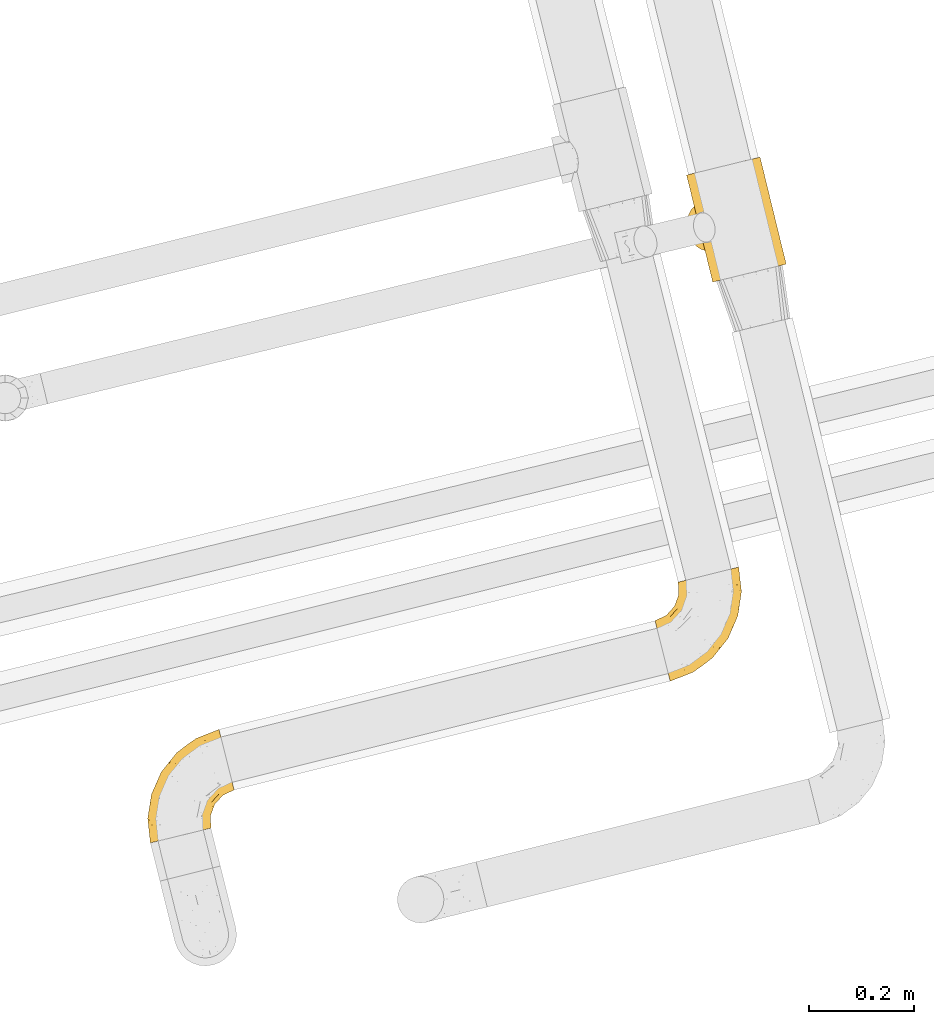
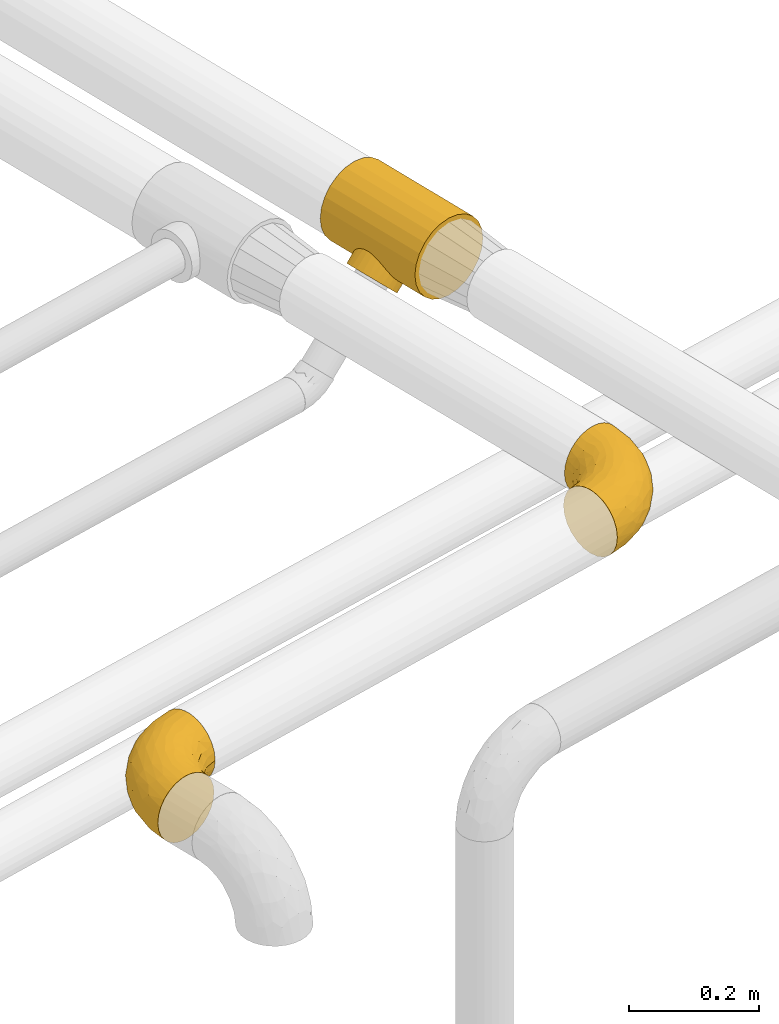
# One storey, part 6 of 93: 3 coverings.
"""IFC2X3 building model written with IfcOpenShell, lengths in millimetres."""

from ifc_helpers import new_model, entity, si_unit, converted_unit, derived_unit, direction, frame, origin, place, context, subcontext, project, spatial, faceted_brep, element, save


model = new_model("IFC2X3")

# Units and contexts
model_context = context("Model", 3, precision=0.01, world=origin(), true_north=direction((6.12303176911189e-17, 1.0)))
body_context = subcontext(model_context, "Body", "Model", "MODEL_VIEW")
ifc_project = project(units=[si_unit("LENGTHUNIT", "METRE", prefix="MILLI"), si_unit("AREAUNIT", "SQUARE_METRE"), si_unit("VOLUMEUNIT", "CUBIC_METRE"), converted_unit("PLANEANGLEUNIT", "DEGREE", entity("IfcRatioMeasure", 0.0174532925199433), si_unit("PLANEANGLEUNIT", "RADIAN"), dimensions=[0, 0, 0, 0, 0, 0, 0]), si_unit("MASSUNIT", "GRAM", prefix="KILO"), derived_unit("MASSDENSITYUNIT", [(si_unit("MASSUNIT", "GRAM", prefix="KILO"), 1), (si_unit("LENGTHUNIT", "METRE"), -3)]), derived_unit("MOMENTOFINERTIAUNIT", [(si_unit("LENGTHUNIT", "METRE"), 4)]), si_unit("TIMEUNIT", "SECOND"), si_unit("FREQUENCYUNIT", "HERTZ"), si_unit("THERMODYNAMICTEMPERATUREUNIT", "DEGREE_CELSIUS"), derived_unit("THERMALTRANSMITTANCEUNIT", [(si_unit("MASSUNIT", "GRAM", prefix="KILO"), 1), (si_unit("THERMODYNAMICTEMPERATUREUNIT", "KELVIN"), -1), (si_unit("TIMEUNIT", "SECOND"), -3)]), derived_unit("VOLUMETRICFLOWRATEUNIT", [(si_unit("LENGTHUNIT", "METRE"), 3), (si_unit("TIMEUNIT", "SECOND"), -1)]), derived_unit("MASSFLOWRATEUNIT", [(si_unit("MASSUNIT", "GRAM", prefix="KILO"), 1), (si_unit("TIMEUNIT", "SECOND"), -1)]), derived_unit("ROTATIONALFREQUENCYUNIT", [(si_unit("TIMEUNIT", "SECOND"), -1)]), si_unit("ELECTRICCURRENTUNIT", "AMPERE"), si_unit("ELECTRICVOLTAGEUNIT", "VOLT"), si_unit("POWERUNIT", "WATT"), si_unit("FORCEUNIT", "NEWTON", prefix="KILO"), si_unit("ILLUMINANCEUNIT", "LUX"), si_unit("LUMINOUSFLUXUNIT", "LUMEN"), si_unit("LUMINOUSINTENSITYUNIT", "CANDELA"), derived_unit("USERDEFINED", [(si_unit("MASSUNIT", "GRAM", prefix="KILO"), -1), (si_unit("LENGTHUNIT", "METRE"), -2), (si_unit("TIMEUNIT", "SECOND"), 3), (si_unit("LUMINOUSFLUXUNIT", "LUMEN"), 1)]), derived_unit("LINEARVELOCITYUNIT", [(si_unit("LENGTHUNIT", "METRE"), 1), (si_unit("TIMEUNIT", "SECOND"), -1)]), si_unit("PRESSUREUNIT", "PASCAL"), derived_unit("USERDEFINED", [(si_unit("LENGTHUNIT", "METRE"), -2), (si_unit("MASSUNIT", "GRAM", prefix="KILO"), 1), (si_unit("TIMEUNIT", "SECOND"), -2)]), derived_unit("LINEARFORCEUNIT", [(si_unit("MASSUNIT", "GRAM", prefix="KILO"), 1), (si_unit("LENGTHUNIT", "METRE"), 1), (si_unit("TIMEUNIT", "SECOND"), -2), (si_unit("LENGTHUNIT", "METRE"), -1)]), derived_unit("PLANARFORCEUNIT", [(si_unit("MASSUNIT", "GRAM", prefix="KILO"), 1), (si_unit("LENGTHUNIT", "METRE"), 1), (si_unit("TIMEUNIT", "SECOND"), -2), (si_unit("LENGTHUNIT", "METRE"), -2)])], contexts=[model_context])

# Site, building, storey
site_placement = place(None, origin())
site = spatial("IfcSite", under=ifc_project, at=site_placement, CompositionType="ELEMENT")
building_placement = place(site_placement, origin())
building = spatial("IfcBuilding", under=site, at=building_placement, CompositionType="ELEMENT")
storey_placement = place(building_placement, frame((0.0, 0.0, -4200.0)))
storey = spatial("IfcBuildingStorey", under=building, at=storey_placement, CompositionType="ELEMENT", Elevation=-4200.0)

# Coverings
covering_1_placement = place(storey_placement, frame((-16263.21, 9717.74, 2404.11)))
element("IfcCovering", 1, at=covering_1_placement, inside=storey, Name=":ADSK_", ObjectType=":ADSK_", PredefinedType="INSULATION", context=body_context, shape_type="Brep", body=[
    faceted_brep([(60.8, 3.9, 132.57), (53.8, 2.19, 115.17), (51.41, 1.6, 96.5), (53.8, 2.17, 77.82), (57.3, 3.02, 69.12), (60.8, 3.87, 60.42), (66.37, 5.23, 52.95), (71.94, 6.59, 45.48), (79.2, 8.36, 39.75), (86.46, 10.13, 34.01), (94.91, 12.19, 30.41), (103.37, 14.25, 26.81), (121.51, 18.68, 24.35), (139.65, 23.11, 26.8), (156.55, 27.24, 34.01), (171.07, 30.79, 45.48), (182.21, 33.52, 60.42), (189.21, 35.24, 77.82), (191.59, 35.83, 96.5), (189.2, 35.25, 115.17), (182.2, 33.55, 132.57), (171.06, 30.83, 147.51), (156.54, 27.29, 158.98), (139.64, 23.17, 166.19), (121.49, 18.74, 168.65), (103.35, 14.31, 166.19), (86.45, 10.18, 158.98), (71.94, 6.63, 147.51), (121.25, 234.8, 45.39), (106.74, 231.25, 33.93), (89.83, 227.12, 26.72), (71.69, 222.69, 24.26), (53.55, 218.26, 26.72), (45.1, 216.2, 30.32), (36.65, 214.13, 33.93), (29.39, 212.36, 39.66), (22.13, 210.59, 45.39), (16.56, 209.24, 52.86), (10.99, 207.88, 60.34), (7.49, 207.03, 69.04), (3.99, 206.18, 77.74), (1.6, 205.6, 96.41), (3.98, 206.19, 115.08), (10.98, 207.91, 132.49), (22.12, 210.63, 147.43), (36.63, 214.18, 158.89), (53.54, 218.31, 166.1), (71.68, 222.75, 168.56), (89.82, 227.17, 166.1), (106.73, 231.3, 158.89), (121.24, 234.84, 147.43), (132.38, 237.55, 132.49), (139.39, 239.26, 115.08), (141.78, 239.83, 96.41), (139.39, 239.24, 77.74), (132.39, 237.52, 60.34), (36.33, 152.45, 45.42), (57.75, 64.73, 45.45), (44.21, 153.14, 38.65), (53.05, 151.76, 33.31), (70.92, 143.42, 26.99), (62.15, 148.46, 29.48), (65.06, 67.74, 38.68), (72.27, 73.04, 33.34), (78.83, 80.17, 29.51), (84.29, 88.68, 27.02), (78.78, 136.74, 25.57), (85.06, 128.46, 24.91), (88.96, 118.82, 24.73), (88.18, 98.23, 25.59), (89.94, 108.47, 24.92), (23.04, 123.15, 82.94), (44.88, 66.37, 61.53), (39.89, 70.67, 69.59), (24.66, 113.73, 87.08), (30.03, 149.69, 53.24), (26.92, 103.7, 88.59), (29.54, 93.75, 87.09), (50.88, 64.29, 53.28), (32.44, 84.64, 82.96), (23.21, 138.96, 69.56), (22.45, 131.6, 76.89), (25.66, 145.08, 61.5), (35.81, 76.86, 76.91), (68.2, 101.71, 2.69), (67.68, 90.38, 5.88), (64.97, 80.09, 10.96), (60.25, 71.56, 17.57), (53.84, 65.35, 25.28), (46.17, 61.9, 33.54), (37.78, 61.44, 41.8), (29.23, 63.99, 49.5), (21.1, 69.4, 56.11), (13.96, 77.28, 61.18), (8.27, 87.1, 64.36), (4.45, 98.2, 65.45), (2.73, 109.81, 64.35), (3.25, 121.14, 61.16), (5.96, 131.43, 56.08), (10.68, 139.96, 49.47), (17.09, 146.17, 41.77), (24.75, 149.62, 33.5), (33.15, 150.08, 25.24), (41.7, 147.53, 17.54), (49.82, 142.12, 10.93), (56.97, 134.24, 5.86), (62.65, 124.41, 2.68), (66.48, 113.32, 1.6)], [[[0, 1, 2, 3, 4, 5, 6, 7, 8, 9, 10, 11, 12, 13, 14, 15, 16, 17, 18, 19, 20, 21, 22, 23, 24, 25, 26, 27]], [[28, 29, 30, 31, 32, 33, 34, 35, 36, 37, 38, 39, 40, 41, 42, 43, 44, 45, 46, 47, 48, 49, 50, 51, 52, 53, 54, 55]], [[35, 56, 36]], [[57, 8, 7]], [[58, 35, 34]], [[34, 59, 58]], [[34, 33, 59]], [[32, 60, 61]], [[61, 33, 32]], [[57, 62, 8]], [[63, 10, 9]], [[63, 64, 10]], [[63, 9, 62]], [[64, 65, 11]], [[66, 31, 67]], [[31, 66, 32]], [[56, 35, 58]], [[59, 33, 61]], [[30, 29, 14, 13]], [[12, 31, 30, 13]], [[67, 31, 68]], [[14, 29, 28, 15]], [[12, 69, 70]], [[62, 9, 8]], [[12, 11, 69]], [[11, 65, 69]], [[70, 68, 12]], [[64, 11, 10]], [[68, 31, 12]], [[66, 60, 32]], [[16, 55, 54, 17]], [[17, 54, 53, 18]], [[28, 55, 16, 15]], [[19, 52, 51, 20]], [[20, 51, 50, 21]], [[18, 53, 52, 19]], [[22, 49, 48, 23]], [[23, 48, 47, 24]], [[50, 49, 22, 21]], [[25, 46, 45, 26]], [[26, 45, 44, 27]], [[24, 47, 46, 25]], [[43, 0, 27, 44]], [[42, 1, 0, 43]], [[41, 40, 71]], [[72, 4, 73]], [[71, 74, 41]], [[75, 38, 37]], [[42, 41, 2, 1]], [[41, 74, 76]], [[76, 77, 2]], [[57, 6, 78]], [[2, 79, 3]], [[79, 2, 77]], [[80, 40, 39]], [[2, 41, 76]], [[71, 40, 81]], [[81, 40, 80]], [[80, 39, 82]], [[36, 56, 37]], [[57, 7, 6]], [[75, 37, 56]], [[38, 75, 82]], [[38, 82, 39]], [[83, 73, 3]], [[4, 72, 5]], [[73, 4, 3]], [[3, 79, 83]], [[6, 5, 78]], [[78, 5, 72]], [[84, 85, 86, 87, 88, 89, 90, 91, 92, 93, 94, 95, 96, 97, 98, 99, 100, 101, 102, 103, 104, 105, 106, 107]], [[62, 89, 88]], [[63, 88, 87]], [[62, 57, 89]], [[64, 63, 87]], [[62, 88, 63]], [[87, 86, 64]], [[86, 85, 65]], [[85, 84, 69]], [[70, 84, 107]], [[65, 85, 69]], [[70, 69, 84]], [[68, 70, 107]], [[86, 65, 64]], [[67, 107, 106]], [[66, 106, 105]], [[68, 107, 67]], [[67, 106, 66]], [[105, 60, 66]], [[105, 104, 60]], [[61, 104, 103]], [[102, 101, 58]], [[59, 103, 102]], [[59, 61, 103]], [[56, 58, 101]], [[59, 102, 58]], [[104, 61, 60]], [[75, 101, 100]], [[82, 100, 99]], [[75, 56, 101]], [[80, 82, 99]], [[75, 100, 82]], [[99, 98, 80]], [[81, 98, 97]], [[97, 96, 71]], [[95, 74, 96]], [[81, 97, 71]], [[74, 71, 96]], [[76, 74, 95]], [[98, 81, 80]], [[77, 95, 94]], [[79, 94, 93]], [[76, 95, 77]], [[77, 94, 79]], [[93, 83, 79]], [[93, 92, 83]], [[73, 92, 91]], [[91, 90, 72]], [[89, 78, 90]], [[72, 73, 91]], [[57, 78, 89]], [[72, 90, 78]], [[92, 73, 83]]]),
])
covering_2_placement = place(storey_placement, frame((-16323.33, 8956.47, 2438.9)))
element("IfcCovering", 2, at=covering_2_placement, inside=storey, Name=":ADSK_", ObjectType=":ADSK_", PredefinedType="INSULATION", context=body_context, shape_type="Brep", body=[
    faceted_brep([(103.39, 204.82, 120.6), (116.24, 208.03, 119.1), (128.44, 211.07, 114.7), (139.39, 213.8, 107.61), (148.53, 216.08, 98.19), (155.4, 217.8, 86.9), (159.67, 218.87, 74.32), (161.12, 219.23, 61.1), (159.67, 218.87, 47.85), (155.4, 217.8, 35.28), (148.52, 216.08, 23.99), (139.38, 213.8, 14.57), (128.43, 211.07, 7.48), (116.22, 208.02, 3.08), (103.39, 204.82, 1.6), (90.54, 201.61, 3.09), (78.34, 198.57, 7.49), (67.39, 195.84, 14.58), (58.25, 193.55, 24.0), (51.37, 191.84, 35.29), (47.1, 190.77, 47.87), (45.66, 190.41, 61.1), (47.11, 190.77, 74.34), (51.38, 191.84, 86.92), (58.26, 193.56, 98.2), (67.4, 195.84, 107.62), (78.35, 198.57, 114.71), (90.55, 201.62, 119.11), (2.09, 115.09, 45.7), (3.52, 109.33, 31.35), (5.81, 100.15, 19.02), (8.79, 88.19, 9.57), (12.26, 74.27, 3.62), (15.99, 59.33, 1.6), (19.72, 44.39, 3.62), (23.19, 30.46, 9.57), (26.17, 18.5, 19.02), (28.46, 9.33, 31.35), (29.89, 3.56, 45.7), (30.38, 1.6, 61.1), (29.89, 3.56, 76.5), (28.46, 9.33, 90.85), (26.17, 18.5, 103.17), (23.19, 30.46, 112.62), (19.72, 44.39, 118.57), (15.99, 59.33, 120.6), (12.26, 74.27, 118.57), (8.79, 88.19, 112.62), (5.81, 100.15, 103.17), (3.52, 109.33, 90.85), (2.09, 115.09, 76.5), (1.6, 117.06, 61.1), (57.73, 23.1, 95.88), (70.0, 21.05, 82.3), (90.82, 41.8, 94.1), (66.56, 15.98, 71.89), (73.99, 18.77, 61.1), (140.74, 180.34, 110.03), (124.66, 65.54, 80.11), (111.66, 46.65, 61.1), (140.83, 83.33, 61.1), (86.81, 72.69, 115.75), (68.2, 50.82, 113.03), (97.99, 63.25, 106.82), (55.42, 56.66, 118.0), (75.76, 79.42, 119.56), (138.15, 95.21, 91.22), (113.86, 67.3, 97.67), (97.86, 40.06, 83.16), (92.57, 31.83, 71.84), (66.02, 38.13, 106.27), (166.43, 172.66, 61.1), (163.61, 175.12, 79.29), (155.83, 141.45, 89.43), (149.91, 105.37, 76.37), (161.49, 140.2, 73.84), (102.6, 106.3, 118.7), (114.53, 99.09, 113.14), (128.85, 143.38, 114.83), (119.21, 159.02, 119.09), (98.23, 130.83, 120.6), (78.89, 98.64, 120.6), (64.72, 86.32, 120.6), (50.55, 74.0, 120.6), (159.51, 126.31, 61.1), (150.96, 171.71, 101.09), (141.11, 140.18, 106.71), (157.93, 185.09, 91.36), (129.48, 178.99, 116.15), (104.68, 190.06, 120.6), (106.67, 167.41, 120.6), (149.37, 141.18, 98.77), (88.56, 114.73, 120.6), (124.92, 92.89, 104.27), (102.45, 149.12, 120.6), (29.63, 65.12, 120.6), (45.93, 103.5, 114.26), (61.41, 122.63, 113.31), (45.26, 119.44, 106.09), (32.07, 82.5, 118.29), (60.9, 98.35, 119.17), (53.33, 136.39, 102.4), (74.5, 114.92, 119.07), (18.92, 122.56, 74.66), (32.75, 134.67, 72.07), (22.95, 127.13, 61.1), (69.25, 172.35, 107.18), (62.72, 157.42, 103.19), (70.4, 145.93, 111.64), (25.42, 96.66, 111.23), (27.07, 110.89, 101.44), (51.53, 177.3, 82.78), (58.76, 174.59, 95.99), (30.2, 124.37, 88.46), (15.59, 116.67, 85.35), (43.22, 149.24, 75.22), (38.82, 144.61, 61.1), (83.98, 162.4, 116.35), (91.25, 146.09, 119.46), (80.35, 142.83, 116.78), (50.75, 160.6, 85.13), (45.3, 141.35, 89.53), (93.05, 182.53, 119.0), (56.23, 160.89, 94.63), (79.4, 181.6, 113.92), (48.3, 167.9, 73.67), (46.8, 166.83, 61.1), (84.7, 129.52, 119.4), (41.43, 127.43, 97.35), (94.99, 161.53, 119.56), (44.5, 91.87, 117.72), (33.96, 105.58, 108.82), (45.25, 119.45, 16.12), (53.32, 136.4, 19.81), (61.39, 122.64, 8.9), (58.75, 174.58, 26.21), (69.24, 172.34, 15.02), (41.43, 127.45, 24.85), (91.25, 146.09, 2.73), (83.97, 162.37, 5.84), (94.98, 161.56, 2.63), (43.23, 149.27, 46.98), (18.91, 122.56, 47.53), (15.59, 116.67, 36.85), (25.42, 96.66, 10.96), (33.96, 105.58, 13.37), (45.93, 103.5, 7.93), (78.89, 98.64, 1.6), (60.9, 98.35, 3.02), (74.51, 114.94, 3.12), (32.07, 82.5, 3.9), (29.63, 65.12, 1.6), (54.14, 151.96, 26.95), (50.75, 160.63, 37.07), (27.06, 110.89, 20.75), (70.38, 145.93, 10.56), (32.75, 134.67, 50.11), (62.7, 157.42, 19.02), (48.3, 167.92, 48.53), (79.39, 181.58, 8.27), (44.5, 91.87, 4.47), (51.53, 177.31, 39.42), (93.04, 182.52, 3.19), (45.3, 141.38, 32.68), (106.67, 167.41, 1.6), (104.68, 190.06, 1.6), (102.45, 149.12, 1.6), (84.71, 129.52, 2.79), (80.34, 142.84, 5.42), (50.55, 74.0, 1.6), (64.72, 86.32, 1.6), (88.56, 114.73, 1.6), (30.19, 124.36, 33.73), (98.23, 130.83, 1.6), (90.82, 41.8, 28.09), (57.73, 23.1, 26.31), (66.02, 38.13, 15.92), (68.2, 50.82, 9.16), (66.56, 15.98, 50.3), (70.0, 21.05, 39.89), (92.57, 31.83, 50.35), (75.76, 79.42, 2.63), (97.99, 63.25, 15.37), (149.91, 105.37, 45.82), (138.15, 95.21, 30.97), (155.83, 141.47, 32.75), (102.6, 106.3, 3.49), (55.42, 56.66, 4.19), (97.86, 40.06, 39.03), (160.47, 139.58, 44.86), (163.6, 175.13, 42.89), (124.66, 65.54, 42.08), (129.47, 178.98, 6.03), (119.21, 159.0, 3.1), (86.81, 72.69, 6.44), (114.53, 99.09, 9.05), (140.73, 180.34, 12.15), (150.95, 171.71, 21.09), (113.86, 67.3, 24.52), (157.93, 185.08, 30.82), (128.84, 143.36, 7.35), (141.1, 140.18, 15.47), (124.92, 92.89, 17.92), (149.36, 141.18, 23.41)], [[[0, 1, 2, 3, 4, 5, 6, 7, 8, 9, 10, 11, 12, 13, 14, 15, 16, 17, 18, 19, 20, 21, 22, 23, 24, 25, 26, 27]], [[28, 29, 30, 31, 32, 33, 34, 35, 36, 37, 38, 39, 40, 41, 42, 43, 44, 45, 46, 47, 48, 49, 50, 51]], [[52, 53, 54]], [[55, 39, 56]], [[57, 3, 2]], [[58, 59, 60]], [[61, 62, 63]], [[64, 61, 65]], [[58, 66, 67]], [[53, 68, 54]], [[41, 40, 53]], [[53, 69, 68]], [[70, 42, 52]], [[42, 41, 52]], [[71, 6, 72]], [[73, 74, 75]], [[43, 70, 62]], [[45, 44, 64]], [[76, 77, 78]], [[79, 80, 76]], [[65, 81, 82, 83]], [[74, 60, 84]], [[85, 3, 57]], [[85, 57, 86]], [[3, 85, 4]], [[42, 70, 43]], [[6, 5, 72]], [[72, 87, 73]], [[5, 4, 87]], [[6, 71, 7]], [[75, 74, 84]], [[64, 62, 61]], [[79, 78, 88]], [[54, 67, 63]], [[74, 58, 60]], [[65, 76, 81]], [[79, 0, 89, 90]], [[75, 71, 72]], [[85, 86, 91]], [[78, 57, 88]], [[56, 69, 55]], [[76, 78, 79]], [[76, 80, 92, 81]], [[77, 76, 61]], [[69, 56, 59]], [[5, 87, 72]], [[91, 66, 73]], [[58, 74, 66]], [[4, 85, 87]], [[73, 87, 85]], [[88, 57, 2]], [[86, 57, 78]], [[77, 86, 78]], [[93, 66, 91]], [[73, 66, 74]], [[67, 93, 63]], [[2, 1, 88]], [[1, 0, 79]], [[1, 79, 88]], [[79, 90, 94, 80]], [[64, 83, 95, 45]], [[76, 65, 61]], [[83, 64, 65]], [[62, 44, 43]], [[62, 64, 44]], [[63, 62, 70]], [[54, 63, 70]], [[63, 93, 77]], [[63, 77, 61]], [[77, 93, 86]], [[67, 54, 68]], [[66, 93, 67]], [[53, 52, 41]], [[70, 52, 54]], [[58, 69, 59]], [[55, 69, 53]], [[69, 58, 68]], [[67, 68, 58]], [[53, 40, 55]], [[39, 55, 40]], [[71, 75, 84]], [[73, 75, 72]], [[91, 86, 93]], [[73, 85, 91]], [[96, 97, 98]], [[83, 99, 95]], [[82, 81, 100]], [[95, 99, 46]], [[101, 98, 97]], [[47, 46, 99]], [[97, 100, 102]], [[103, 104, 105]], [[106, 107, 108]], [[109, 48, 47]], [[48, 110, 49]], [[108, 101, 97]], [[111, 112, 23]], [[51, 50, 103]], [[113, 103, 114]], [[24, 23, 112]], [[115, 116, 104]], [[108, 117, 106]], [[112, 106, 24]], [[94, 118, 80]], [[108, 119, 117]], [[120, 115, 121]], [[112, 107, 106]], [[26, 122, 27]], [[122, 89, 27]], [[101, 123, 121]], [[109, 110, 48]], [[124, 26, 25]], [[125, 21, 126]], [[120, 111, 125]], [[110, 113, 114]], [[127, 97, 102]], [[106, 25, 24]], [[125, 115, 120]], [[111, 23, 22]], [[126, 115, 125]], [[117, 124, 106]], [[110, 98, 128]], [[117, 129, 124]], [[117, 118, 129]], [[100, 97, 96]], [[124, 122, 26]], [[83, 82, 130]], [[99, 130, 109]], [[100, 81, 102]], [[100, 130, 82]], [[130, 100, 96]], [[81, 92, 102]], [[127, 80, 118]], [[22, 21, 125]], [[111, 120, 123]], [[22, 125, 111]], [[115, 126, 116]], [[104, 116, 105]], [[101, 107, 123]], [[104, 121, 115]], [[128, 121, 113]], [[105, 51, 103]], [[121, 104, 113]], [[114, 103, 50]], [[113, 104, 103]], [[106, 124, 25]], [[94, 129, 118]], [[123, 107, 112]], [[101, 108, 107]], [[99, 109, 47]], [[131, 109, 96]], [[89, 122, 90]], [[89, 0, 27]], [[122, 129, 90]], [[97, 127, 119]], [[119, 127, 118]], [[102, 92, 127]], [[90, 129, 94]], [[80, 127, 92]], [[124, 129, 122]], [[117, 119, 118]], [[97, 119, 108]], [[50, 49, 114]], [[110, 114, 49]], [[109, 130, 96]], [[130, 99, 83]], [[128, 98, 101]], [[98, 110, 131]], [[121, 128, 101]], [[110, 128, 113]], [[46, 45, 95]], [[111, 123, 112]], [[121, 123, 120]], [[98, 131, 96]], [[110, 109, 131]], [[132, 133, 134]], [[135, 18, 136]], [[132, 137, 133]], [[138, 139, 140]], [[126, 141, 116]], [[105, 142, 51]], [[17, 136, 18]], [[142, 143, 28]], [[144, 145, 146]], [[147, 148, 149]], [[31, 150, 32]], [[150, 151, 32]], [[135, 152, 153]], [[30, 29, 154]], [[155, 136, 139]], [[31, 30, 144]], [[156, 116, 141]], [[136, 155, 157]], [[126, 158, 141]], [[134, 149, 148]], [[21, 20, 158]], [[156, 142, 105]], [[159, 136, 17]], [[148, 160, 146]], [[135, 19, 18]], [[19, 161, 20]], [[136, 157, 135]], [[146, 145, 132]], [[159, 162, 140]], [[17, 16, 159]], [[16, 15, 162]], [[163, 141, 153]], [[133, 155, 134]], [[152, 135, 157]], [[164, 162, 165]], [[162, 15, 165]], [[161, 135, 153]], [[29, 143, 154]], [[164, 166, 140]], [[161, 158, 20]], [[138, 167, 168]], [[166, 138, 140]], [[144, 150, 31]], [[160, 169, 150]], [[170, 169, 160]], [[147, 170, 148]], [[134, 148, 146]], [[134, 155, 168]], [[167, 171, 149]], [[135, 161, 19]], [[158, 161, 153]], [[158, 153, 141]], [[158, 126, 21]], [[153, 152, 163]], [[116, 156, 105]], [[137, 163, 133]], [[156, 163, 172]], [[163, 156, 141]], [[142, 28, 51]], [[156, 172, 142]], [[143, 142, 172]], [[162, 159, 16]], [[136, 159, 139]], [[155, 133, 157]], [[133, 163, 152]], [[154, 144, 30]], [[144, 146, 160]], [[15, 14, 165]], [[167, 138, 173]], [[138, 166, 173]], [[139, 138, 168]], [[171, 147, 149]], [[167, 149, 134]], [[167, 173, 171]], [[159, 140, 139]], [[164, 140, 162]], [[134, 168, 167]], [[139, 168, 155]], [[154, 143, 172]], [[29, 28, 143]], [[170, 160, 148]], [[144, 160, 150]], [[146, 132, 134]], [[137, 154, 172]], [[154, 137, 132]], [[163, 137, 172]], [[151, 150, 169]], [[151, 33, 32]], [[133, 152, 157]], [[144, 154, 145]], [[132, 145, 154]], [[174, 175, 176]], [[35, 34, 177]], [[178, 179, 180]], [[181, 169, 170, 147]], [[176, 182, 174]], [[183, 184, 185]], [[186, 147, 171, 173]], [[187, 33, 151, 169]], [[179, 188, 180]], [[34, 187, 177]], [[39, 38, 178]], [[189, 185, 190]], [[184, 183, 191]], [[175, 179, 37]], [[38, 37, 179]], [[35, 176, 36]], [[180, 59, 56]], [[192, 193, 13]], [[37, 36, 175]], [[181, 187, 169]], [[181, 186, 194]], [[176, 177, 182]], [[9, 8, 190]], [[194, 186, 195]], [[14, 13, 193]], [[196, 192, 12]], [[11, 10, 197]], [[60, 183, 84]], [[174, 182, 198]], [[197, 196, 11]], [[193, 173, 166, 164]], [[9, 199, 10]], [[189, 183, 185]], [[60, 59, 191]], [[200, 196, 201]], [[190, 199, 9]], [[8, 7, 71]], [[11, 196, 12]], [[202, 203, 184]], [[199, 185, 197]], [[8, 71, 190]], [[183, 60, 191]], [[189, 71, 84]], [[193, 186, 173]], [[200, 201, 195]], [[180, 191, 59]], [[185, 199, 190]], [[197, 10, 199]], [[201, 196, 197]], [[192, 196, 200]], [[203, 201, 197]], [[195, 201, 202]], [[191, 188, 198]], [[202, 201, 203]], [[193, 192, 200]], [[13, 12, 192]], [[186, 193, 200]], [[193, 164, 165, 14]], [[186, 181, 147]], [[187, 181, 194]], [[187, 194, 177]], [[187, 34, 33]], [[194, 195, 182]], [[35, 177, 176]], [[194, 182, 177]], [[182, 202, 198]], [[200, 195, 186]], [[182, 195, 202]], [[202, 184, 198]], [[191, 198, 184]], [[176, 175, 36]], [[179, 175, 174]], [[178, 180, 56]], [[179, 174, 188]], [[198, 188, 174]], [[191, 180, 188]], [[39, 178, 56]], [[38, 179, 178]], [[71, 189, 190]], [[84, 183, 189]], [[197, 185, 203]], [[184, 203, 185]]]),
])
covering_3_placement = place(storey_placement, frame((-17290.9, 8648.24, 2438.9)))
element("IfcCovering", 3, at=covering_3_placement, inside=storey, Name=":ADSK_", ObjectType=":ADSK_", PredefinedType="INSULATION", context=body_context, shape_type="Brep", body=[
    faceted_brep([(122.24, 29.57, 61.1), (120.79, 29.22, 74.34), (116.51, 28.19, 86.92), (109.62, 26.52, 98.2), (100.46, 24.3, 107.62), (89.49, 21.65, 114.71), (77.27, 18.69, 119.11), (64.41, 15.58, 120.6), (51.54, 12.47, 119.1), (39.31, 9.51, 114.7), (28.35, 6.86, 107.61), (19.19, 4.65, 98.19), (12.3, 2.98, 86.9), (8.03, 1.95, 74.32), (6.58, 1.6, 61.1), (8.03, 1.95, 47.85), (12.31, 2.98, 35.28), (19.2, 4.65, 23.99), (28.36, 6.86, 14.57), (39.33, 9.52, 7.48), (51.55, 12.47, 3.08), (64.41, 15.58, 1.6), (77.28, 18.7, 3.09), (89.51, 21.65, 7.49), (100.47, 24.31, 14.58), (109.63, 26.52, 24.0), (116.52, 28.19, 35.29), (120.79, 29.22, 47.87), (165.92, 104.47, 45.7), (164.48, 110.23, 31.35), (162.19, 119.41, 19.02), (159.21, 131.37, 9.57), (155.74, 145.29, 3.62), (152.02, 160.23, 1.6), (148.29, 175.17, 3.62), (144.82, 189.1, 9.57), (141.84, 201.05, 19.02), (139.55, 210.23, 31.35), (138.11, 216.0, 45.7), (137.62, 217.96, 61.1), (138.11, 216.0, 76.5), (139.55, 210.23, 90.85), (141.84, 201.05, 103.17), (144.82, 189.1, 112.62), (148.29, 175.17, 118.57), (152.02, 160.23, 120.6), (155.74, 145.29, 118.57), (159.21, 131.37, 112.62), (162.19, 119.41, 103.17), (164.48, 110.23, 90.85), (165.92, 104.47, 76.5), (166.41, 102.5, 61.1), (110.33, 196.48, 95.89), (98.04, 198.53, 82.31), (77.27, 177.81, 94.12), (101.8, 203.75, 71.9), (94.21, 200.89, 61.1), (27.25, 40.33, 110.04), (43.67, 154.44, 80.08), (56.66, 173.21, 61.1), (27.51, 136.79, 61.1), (81.56, 147.04, 115.81), (100.15, 168.88, 113.07), (70.41, 156.44, 106.97), (112.82, 162.91, 118.03), (92.52, 140.31, 119.58), (30.11, 124.68, 91.34), (54.57, 152.5, 97.87), (70.06, 179.44, 83.14), (75.69, 187.92, 71.82), (102.02, 181.43, 106.28), (1.6, 47.98, 61.1), (4.41, 45.72, 79.3), (12.44, 79.32, 89.44), (18.38, 114.89, 76.31), (6.7, 80.31, 73.78), (65.73, 113.64, 118.72), (53.93, 120.91, 113.23), (39.35, 76.74, 114.87), (48.97, 61.49, 119.1), (69.97, 89.22, 120.6), (89.34, 121.19, 120.6), (103.47, 133.42, 120.6), (117.6, 145.65, 120.6), (8.73, 94.08, 61.1), (17.08, 49.04, 101.1), (27.2, 80.57, 106.73), (10.01, 35.72, 91.36), (38.71, 41.25, 116.23), (63.21, 30.35, 120.6), (61.39, 52.84, 120.6), (18.91, 79.57, 98.79), (79.66, 105.2, 120.6), (43.55, 127.07, 104.46), (65.68, 71.03, 120.6), (138.38, 154.45, 120.6), (122.13, 116.05, 114.24), (107.04, 97.05, 113.15), (123.01, 100.13, 105.93), (135.94, 137.04, 118.29), (107.31, 121.37, 119.16), (114.89, 83.37, 102.31), (88.1, 90.26, 118.38), (94.27, 107.66, 119.32), (149.17, 97.04, 74.61), (135.39, 85.0, 71.94), (145.15, 92.49, 61.1), (97.86, 74.11, 111.6), (84.14, 57.94, 116.35), (98.8, 47.82, 107.17), (142.6, 122.89, 111.22), (141.01, 108.68, 101.41), (116.47, 42.72, 82.77), (109.27, 45.48, 95.98), (137.93, 95.27, 88.42), (152.46, 102.87, 85.26), (124.95, 70.65, 75.21), (129.3, 75.14, 61.1), (105.46, 62.63, 103.14), (76.84, 74.01, 119.47), (87.54, 72.96, 116.36), (117.37, 59.4, 85.11), (122.95, 78.56, 89.47), (74.93, 37.77, 118.99), (111.9, 59.13, 94.6), (88.56, 38.68, 113.92), (119.76, 52.09, 73.66), (121.26, 53.05, 61.1), (126.73, 92.16, 97.23), (73.11, 58.42, 119.56), (123.69, 127.66, 117.68), (134.08, 113.97, 108.8), (123.02, 100.12, 16.27), (114.9, 83.36, 19.89), (107.06, 97.04, 9.06), (109.28, 45.48, 26.23), (98.81, 47.83, 15.03), (126.74, 92.15, 24.98), (84.16, 57.97, 5.84), (73.11, 58.39, 2.64), (76.84, 74.01, 2.72), (124.94, 70.62, 47.0), (149.17, 97.04, 47.58), (152.46, 102.87, 36.94), (142.6, 122.89, 10.97), (134.08, 113.97, 13.39), (122.13, 116.05, 7.96), (107.31, 121.37, 3.03), (94.27, 107.66, 2.87), (89.34, 121.19, 1.6), (135.94, 137.04, 3.91), (138.38, 154.45, 1.6), (114.05, 68.04, 26.99), (117.37, 59.37, 37.1), (141.01, 108.68, 20.78), (97.88, 74.11, 10.6), (135.39, 85.0, 50.23), (105.47, 62.64, 19.06), (119.76, 52.06, 48.54), (88.12, 90.27, 3.81), (88.57, 38.7, 8.27), (129.99, 127.23, 5.88), (118.25, 132.62, 2.66), (116.47, 42.7, 39.44), (74.94, 37.78, 3.2), (122.94, 78.53, 32.74), (61.39, 52.84, 1.6), (63.21, 30.35, 1.6), (65.68, 71.03, 1.6), (87.55, 73.01, 5.83), (79.66, 105.2, 1.6), (117.6, 145.65, 1.6), (103.47, 133.42, 1.6), (137.94, 95.28, 33.77), (69.97, 89.22, 1.6), (77.27, 177.81, 28.07), (110.33, 196.48, 26.3), (102.02, 181.43, 15.91), (100.15, 168.88, 9.12), (101.8, 203.75, 50.29), (98.04, 198.53, 39.88), (75.69, 187.92, 50.37), (92.52, 140.31, 2.61), (43.46, 84.14, 6.38), (50.03, 44.58, 2.62), (38.43, 44.35, 6.06), (43.55, 127.07, 17.74), (33.42, 92.27, 13.26), (26.73, 112.84, 27.42), (54.5, 77.53, 2.61), (65.73, 113.64, 3.47), (112.82, 162.91, 4.16), (70.06, 179.44, 39.05), (20.43, 77.65, 21.2), (17.53, 38.97, 20.6), (12.44, 79.31, 32.73), (9.91, 35.42, 31.03), (26.66, 55.17, 12.84), (76.32, 154.82, 11.34), (52.89, 119.73, 9.12), (4.41, 45.71, 42.88), (68.52, 158.84, 17.9), (47.99, 148.47, 27.77), (81.56, 147.04, 6.38), (18.38, 114.89, 45.88), (7.79, 81.0, 44.75), (43.67, 154.44, 42.11)], [[[0, 1, 2, 3, 4, 5, 6, 7, 8, 9, 10, 11, 12, 13, 14, 15, 16, 17, 18, 19, 20, 21, 22, 23, 24, 25, 26, 27]], [[28, 29, 30, 31, 32, 33, 34, 35, 36, 37, 38, 39, 40, 41, 42, 43, 44, 45, 46, 47, 48, 49, 50, 51]], [[52, 53, 54]], [[55, 39, 56]], [[57, 10, 9]], [[58, 59, 60]], [[61, 62, 63]], [[64, 61, 65]], [[58, 66, 67]], [[53, 68, 54]], [[41, 40, 53]], [[53, 69, 68]], [[70, 42, 52]], [[42, 41, 52]], [[71, 13, 72]], [[73, 74, 75]], [[43, 70, 62]], [[45, 44, 64]], [[76, 77, 78]], [[79, 80, 76]], [[65, 81, 82, 83]], [[74, 60, 84]], [[85, 10, 57]], [[85, 57, 86]], [[10, 85, 11]], [[42, 70, 43]], [[13, 12, 72]], [[72, 87, 73]], [[12, 11, 87]], [[13, 71, 14]], [[75, 74, 84]], [[64, 62, 61]], [[79, 78, 88]], [[54, 67, 63]], [[74, 58, 60]], [[65, 76, 81]], [[79, 7, 89, 90]], [[75, 71, 72]], [[85, 86, 91]], [[8, 88, 9]], [[56, 69, 55]], [[76, 78, 79]], [[76, 80, 92, 81]], [[77, 76, 61]], [[69, 56, 59]], [[12, 87, 72]], [[91, 66, 73]], [[58, 74, 66]], [[11, 85, 87]], [[73, 87, 85]], [[88, 57, 9]], [[86, 57, 78]], [[77, 86, 78]], [[93, 66, 91]], [[73, 66, 74]], [[67, 93, 63]], [[8, 7, 79]], [[57, 88, 78]], [[8, 79, 88]], [[79, 90, 94, 80]], [[64, 83, 95, 45]], [[76, 65, 61]], [[83, 64, 65]], [[62, 44, 43]], [[62, 64, 44]], [[63, 62, 70]], [[54, 63, 70]], [[63, 93, 77]], [[63, 77, 61]], [[77, 93, 86]], [[67, 54, 68]], [[66, 93, 67]], [[53, 52, 41]], [[70, 52, 54]], [[58, 69, 59]], [[55, 69, 53]], [[69, 58, 68]], [[67, 68, 58]], [[53, 40, 55]], [[39, 55, 40]], [[71, 75, 84]], [[73, 75, 72]], [[91, 86, 93]], [[73, 85, 91]], [[96, 97, 98]], [[83, 99, 95]], [[82, 81, 100]], [[95, 99, 46]], [[101, 98, 97]], [[47, 46, 99]], [[102, 103, 92]], [[104, 105, 106]], [[107, 108, 109]], [[110, 48, 47]], [[48, 111, 49]], [[107, 101, 97]], [[112, 113, 2]], [[51, 50, 104]], [[114, 104, 115]], [[3, 2, 113]], [[116, 117, 105]], [[109, 118, 107]], [[113, 109, 3]], [[102, 119, 120]], [[120, 119, 108]], [[121, 116, 122]], [[113, 118, 109]], [[5, 123, 6]], [[123, 89, 6]], [[101, 124, 122]], [[110, 111, 48]], [[125, 5, 4]], [[126, 0, 127]], [[121, 112, 126]], [[111, 114, 115]], [[97, 102, 107]], [[127, 116, 126]], [[126, 116, 121]], [[112, 2, 1]], [[109, 4, 3]], [[108, 125, 109]], [[111, 98, 128]], [[108, 129, 125]], [[108, 119, 129]], [[103, 96, 100]], [[125, 123, 5]], [[96, 103, 97]], [[119, 80, 94]], [[83, 82, 130]], [[99, 130, 110]], [[100, 81, 103]], [[100, 130, 82]], [[130, 100, 96]], [[1, 0, 126]], [[112, 121, 124]], [[1, 126, 112]], [[116, 127, 117]], [[105, 117, 106]], [[101, 118, 124]], [[105, 122, 116]], [[128, 122, 114]], [[92, 80, 102]], [[97, 103, 102]], [[103, 81, 92]], [[106, 51, 104]], [[122, 105, 114]], [[115, 104, 50]], [[114, 105, 104]], [[109, 125, 4]], [[94, 129, 119]], [[124, 118, 113]], [[101, 107, 118]], [[99, 110, 47]], [[131, 110, 96]], [[89, 123, 90]], [[89, 7, 6]], [[123, 129, 90]], [[102, 80, 119]], [[90, 129, 94]], [[125, 129, 123]], [[50, 49, 115]], [[111, 115, 49]], [[108, 107, 120]], [[102, 120, 107]], [[110, 130, 96]], [[130, 99, 83]], [[128, 98, 101]], [[98, 111, 131]], [[122, 128, 101]], [[111, 128, 114]], [[46, 45, 95]], [[112, 124, 113]], [[122, 124, 121]], [[98, 131, 96]], [[111, 110, 131]], [[132, 133, 134]], [[135, 25, 136]], [[132, 137, 133]], [[138, 139, 140]], [[127, 141, 117]], [[106, 142, 51]], [[24, 136, 25]], [[142, 143, 28]], [[144, 145, 146]], [[147, 148, 149]], [[31, 150, 32]], [[150, 151, 32]], [[135, 152, 153]], [[30, 29, 154]], [[155, 136, 138]], [[31, 30, 144]], [[156, 117, 141]], [[136, 155, 157]], [[127, 158, 141]], [[159, 148, 134]], [[0, 27, 158]], [[156, 142, 106]], [[160, 136, 24]], [[161, 147, 162]], [[135, 26, 25]], [[26, 163, 27]], [[136, 157, 135]], [[146, 145, 132]], [[160, 164, 139]], [[24, 23, 160]], [[23, 22, 164]], [[165, 141, 153]], [[133, 155, 134]], [[152, 135, 157]], [[166, 164, 167]], [[164, 22, 167]], [[163, 135, 153]], [[29, 143, 154]], [[166, 168, 139]], [[163, 158, 27]], [[159, 134, 155]], [[168, 140, 139]], [[140, 169, 138]], [[159, 170, 148]], [[144, 150, 31]], [[162, 171, 150]], [[162, 147, 172]], [[149, 172, 147]], [[148, 146, 134]], [[135, 163, 26]], [[158, 163, 153]], [[158, 153, 141]], [[158, 127, 0]], [[153, 152, 165]], [[117, 156, 106]], [[137, 165, 133]], [[156, 165, 173]], [[148, 147, 146]], [[165, 156, 141]], [[170, 159, 174]], [[170, 149, 148]], [[142, 28, 51]], [[156, 173, 142]], [[143, 142, 173]], [[164, 160, 23]], [[136, 160, 138]], [[155, 133, 157]], [[133, 165, 152]], [[154, 144, 30]], [[161, 162, 150]], [[22, 21, 167]], [[174, 159, 140]], [[140, 168, 174]], [[169, 159, 155]], [[160, 139, 138]], [[166, 139, 164]], [[154, 143, 173]], [[29, 28, 143]], [[159, 169, 140]], [[155, 138, 169]], [[171, 162, 172]], [[150, 144, 161]], [[144, 146, 161]], [[147, 161, 146]], [[146, 132, 134]], [[137, 154, 173]], [[154, 137, 132]], [[165, 137, 173]], [[151, 150, 171]], [[151, 33, 32]], [[133, 152, 157]], [[144, 154, 145]], [[132, 145, 154]], [[175, 176, 177]], [[35, 34, 178]], [[179, 180, 181]], [[182, 171, 172, 149]], [[183, 184, 185]], [[186, 187, 188]], [[189, 190, 174]], [[191, 33, 151, 171]], [[180, 192, 181]], [[34, 191, 178]], [[39, 38, 179]], [[193, 194, 195]], [[17, 16, 196]], [[176, 180, 37]], [[38, 37, 180]], [[35, 177, 36]], [[181, 59, 56]], [[182, 191, 171]], [[37, 36, 176]], [[185, 19, 197]], [[190, 149, 170, 174]], [[186, 198, 199]], [[16, 15, 200]], [[201, 186, 202]], [[21, 20, 184]], [[199, 203, 190]], [[185, 20, 19]], [[60, 204, 84]], [[202, 186, 188]], [[18, 197, 19]], [[199, 183, 187]], [[196, 16, 200]], [[205, 204, 195]], [[60, 59, 206]], [[197, 193, 187]], [[18, 194, 197]], [[15, 14, 71]], [[197, 194, 193]], [[194, 18, 17]], [[195, 194, 196]], [[15, 71, 200]], [[204, 60, 206]], [[205, 71, 84]], [[189, 174, 168, 166]], [[182, 190, 203]], [[181, 206, 59]], [[197, 183, 185]], [[183, 189, 184]], [[201, 175, 177]], [[205, 195, 200]], [[188, 193, 195]], [[197, 187, 183]], [[195, 204, 188]], [[206, 188, 204]], [[188, 206, 202]], [[192, 202, 206]], [[188, 187, 193]], [[199, 187, 186]], [[186, 201, 198]], [[190, 183, 199]], [[175, 201, 202]], [[177, 178, 198]], [[190, 182, 149]], [[191, 182, 203]], [[191, 203, 178]], [[191, 34, 33]], [[189, 166, 184]], [[190, 189, 183]], [[184, 166, 167, 21]], [[20, 185, 184]], [[198, 178, 203]], [[35, 178, 177]], [[177, 176, 36]], [[180, 176, 175]], [[199, 198, 203]], [[177, 198, 201]], [[179, 181, 56]], [[180, 175, 192]], [[202, 192, 175]], [[206, 181, 192]], [[39, 179, 56]], [[38, 180, 179]], [[195, 196, 200]], [[17, 196, 194]], [[71, 205, 200]], [[84, 204, 205]]]),
])

save(model, "model.ifc")
